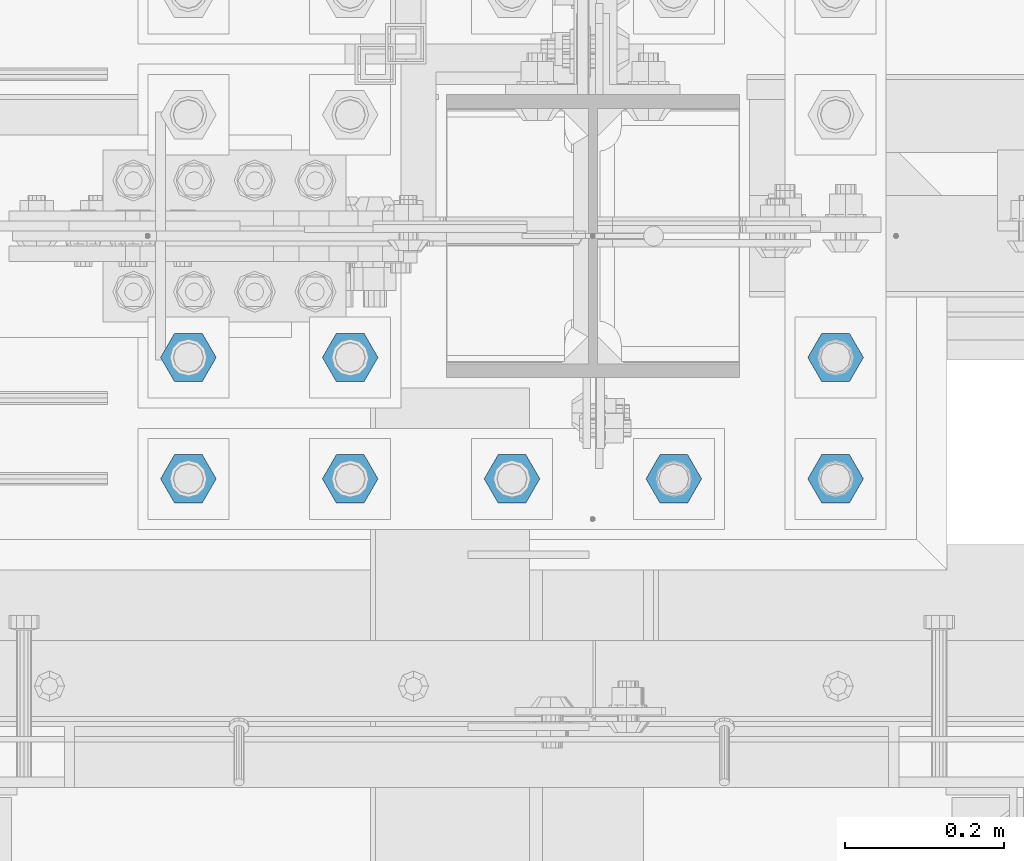
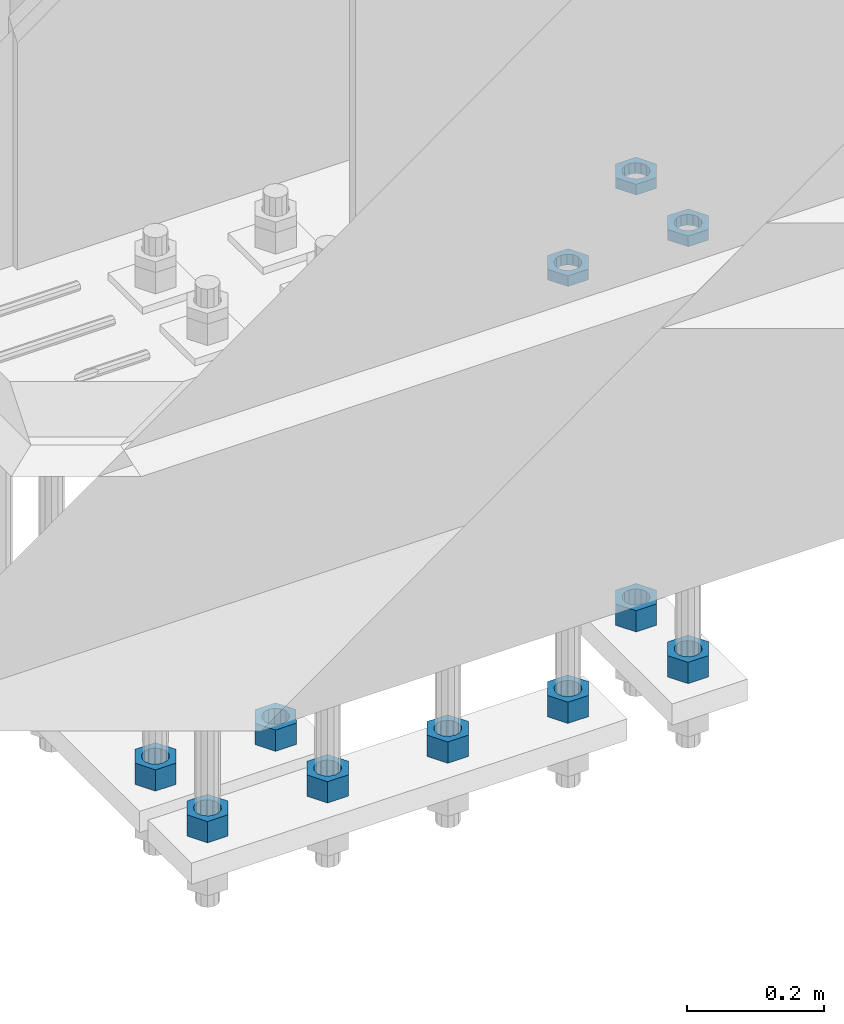
# One storey, part 2813 of 3843: 11 beams, 1 element without a shape of its own.
"""IFC2X3 building model written with IfcOpenShell, lengths in millimetres."""

from ifc_helpers import new_model, si_unit, frame, origin_with_axes, place, context, subcontext, project, spatial, faceted_brep, material, type_object, element, aggregate, save


model = new_model("IFC2X3")

# Units and contexts
model_context = context("Model", 3, precision=1e-05, world=origin_with_axes())
body_context = subcontext(model_context, "Body", "Model", "MODEL_VIEW")
ifc_project = project(units=[si_unit("LENGTHUNIT", "METRE", prefix="MILLI"), si_unit("AREAUNIT", "SQUARE_METRE"), si_unit("VOLUMEUNIT", "CUBIC_METRE"), si_unit("MASSUNIT", "GRAM", prefix="KILO"), si_unit("TIMEUNIT", "SECOND"), si_unit("PLANEANGLEUNIT", "RADIAN"), si_unit("SOLIDANGLEUNIT", "STERADIAN"), si_unit("THERMODYNAMICTEMPERATUREUNIT", "DEGREE_CELSIUS"), si_unit("LUMINOUSINTENSITYUNIT", "LUMEN")], contexts=[model_context])

# Site, building, storey
site_placement = place(None, origin_with_axes())
site = spatial("IfcSite", under=ifc_project, at=site_placement, CompositionType="ELEMENT")
building_placement = place(site_placement, origin_with_axes())
building = spatial("IfcBuilding", under=site, at=building_placement, Name="Undefined", CompositionType="ELEMENT")
storey_placement = place(building_placement, origin_with_axes())
storey = spatial("IfcBuildingStorey", under=building, at=storey_placement, Name="Undefined", CompositionType="ELEMENT", Elevation=0.0)

# Assembly, beams
assembly_placement = place(storey_placement, origin_with_axes())
assembly = element("IfcElementAssembly", 1, at=assembly_placement, inside=storey, Name="TEMPLATE", AssemblyPlace="NOTDEFINED", PredefinedType="RIGID_FRAME")
ifc_material = material(Name="STEEL/A572-50")
beam_type_1 = type_object("IfcBeamType", Name="1-1/2_HEAVY_HEX_NUT", PredefinedType="NOTDEFINED")
beam_1_placement = place(assembly_placement, frame((48488.6, 25463.5, 28841.7000015259), z_axis=(0.0, 1.0, 0.0), x_axis=(0.0, 0.0, -1.0)))
beam_1 = element("IfcBeam", 2, at=beam_1_placement, type_object=beam_type_1, material=ifc_material, Name="NUT", ObjectType="1-1/2_HEAVY_HEX_NUT", context=body_context, shape_type="Brep", body=[
    faceted_brep([(0.0, -34.9199981689453, 0.0), (0.0, -17.4599990844727, -30.25), (38.0999999999985, -17.4599990844727, -30.25), (38.0999999999985, -34.9199981689453, 0.0), (0.0, 17.4599990844727, -30.25), (38.0999999999985, 17.4599990844727, -30.25), (0.0, 34.9199981689453, 0.0), (38.0999999999985, 34.9199981689453, 0.0), (0.0, 17.4599990844727, 30.25), (38.0999999999985, 17.4599990844727, 30.25), (0.0, -17.4599990844727, 30.25), (38.0999999999985, -17.4599990844727, 30.25), (0.0, 0.0, 20.6399993896484), (0.0, 8.9553601105581, 18.5959968835959), (38.0999999999985, 8.9553601105581, 18.5959968835959), (38.0999999999985, 0.0, 20.6399993896484), (0.0, 16.1370013209525, 12.8688291298167), (38.0999999999985, 16.1370013209525, 12.8688291298167), (0.0, 20.1225115123816, 4.59283194104501), (38.0999999999985, 20.1225115123816, 4.59283194104501), (0.0, 20.1225115123816, -4.59283194104501), (38.0999999999985, 20.1225115123816, -4.59283194104501), (0.0, 16.1370013209525, -12.8688291298167), (38.0999999999985, 16.1370013209525, -12.8688291298167), (0.0, 8.9553601105581, -18.5959968835959), (38.0999999999985, 8.9553601105581, -18.5959968835959), (0.0, 0.0, -20.6399993896484), (38.0999999999985, 0.0, -20.6399993896484), (0.0, -8.9553601105581, -18.5959968835959), (38.0999999999985, -8.9553601105581, -18.5959968835959), (0.0, -16.1370013209525, -12.8688291298167), (38.0999999999985, -16.1370013209525, -12.8688291298167), (0.0, -20.1225115123816, -4.59283194104501), (38.0999999999985, -20.1225115123816, -4.59283194104501), (0.0, -20.1225115123816, 4.59283194104501), (38.0999999999985, -20.1225115123816, 4.59283194104501), (0.0, -16.1370013209525, 12.8688291298167), (38.0999999999985, -16.1370013209525, 12.8688291298167), (0.0, -8.9553601105581, 18.5959968835959), (38.0999999999985, -8.9553601105581, 18.5959968835959)], [[[0, 1, 2, 3]], [[1, 4, 5, 2]], [[4, 6, 7, 5]], [[6, 8, 9, 7]], [[8, 10, 11, 9]], [[10, 0, 3, 11]], [[12, 13, 14, 15]], [[13, 16, 17, 14]], [[16, 18, 19, 17]], [[18, 20, 21, 19]], [[20, 22, 23, 21]], [[22, 24, 25, 23]], [[24, 26, 27, 25]], [[26, 28, 29, 27]], [[28, 30, 31, 29]], [[30, 32, 33, 31]], [[32, 34, 35, 33]], [[34, 36, 37, 35]], [[36, 38, 39, 37]], [[38, 12, 15, 39]], [[5, 7, 9, 11, 3, 2], [17, 19, 21, 23, 25, 27, 29, 31, 33, 35, 37, 39, 15, 14]], [[10, 8, 6, 4, 1, 0], [38, 36, 34, 32, 30, 28, 26, 24, 22, 20, 18, 16, 13, 12]]]),
])
beam_2_placement = place(assembly_placement, frame((48691.8, 25463.5, 28841.7000015259), z_axis=(0.0, 1.0, 0.0), x_axis=(0.0, 0.0, -1.0)))
beam_2 = element("IfcBeam", 3, at=beam_2_placement, type_object=beam_type_1, material=ifc_material, Name="NUT", ObjectType="1-1/2_HEAVY_HEX_NUT", context=body_context, shape_type="Brep", body=[
    faceted_brep([(0.0, -34.9199981689453, 0.0), (0.0, -17.4599990844727, -30.25), (38.0999999999985, -17.4599990844727, -30.25), (38.0999999999985, -34.9199981689453, 0.0), (0.0, 17.4599990844727, -30.25), (38.0999999999985, 17.4599990844727, -30.25), (0.0, 34.9199981689453, 0.0), (38.0999999999985, 34.9199981689453, 0.0), (0.0, 17.4599990844727, 30.25), (38.0999999999985, 17.4599990844727, 30.25), (0.0, -17.4599990844727, 30.25), (38.0999999999985, -17.4599990844727, 30.25), (0.0, 0.0, 20.6399993896484), (0.0, 8.9553601105581, 18.5959968835959), (38.0999999999985, 8.9553601105581, 18.5959968835959), (38.0999999999985, 0.0, 20.6399993896484), (0.0, 16.1370013209525, 12.8688291298167), (38.0999999999985, 16.1370013209525, 12.8688291298167), (0.0, 20.1225115123816, 4.59283194104501), (38.0999999999985, 20.1225115123816, 4.59283194104501), (0.0, 20.1225115123816, -4.59283194104501), (38.0999999999985, 20.1225115123816, -4.59283194104501), (0.0, 16.1370013209525, -12.8688291298167), (38.0999999999985, 16.1370013209525, -12.8688291298167), (0.0, 8.9553601105581, -18.5959968835959), (38.0999999999985, 8.9553601105581, -18.5959968835959), (0.0, 0.0, -20.6399993896484), (38.0999999999985, 0.0, -20.6399993896484), (0.0, -8.9553601105581, -18.5959968835959), (38.0999999999985, -8.9553601105581, -18.5959968835959), (0.0, -16.1370013209525, -12.8688291298167), (38.0999999999985, -16.1370013209525, -12.8688291298167), (0.0, -20.1225115123816, -4.59283194104501), (38.0999999999985, -20.1225115123816, -4.59283194104501), (0.0, -20.1225115123816, 4.59283194104501), (38.0999999999985, -20.1225115123816, 4.59283194104501), (0.0, -16.1370013209525, 12.8688291298167), (38.0999999999985, -16.1370013209525, 12.8688291298167), (0.0, -8.9553601105581, 18.5959968835959), (38.0999999999985, -8.9553601105581, 18.5959968835959)], [[[0, 1, 2, 3]], [[1, 4, 5, 2]], [[4, 6, 7, 5]], [[6, 8, 9, 7]], [[8, 10, 11, 9]], [[10, 0, 3, 11]], [[12, 13, 14, 15]], [[13, 16, 17, 14]], [[16, 18, 19, 17]], [[18, 20, 21, 19]], [[20, 22, 23, 21]], [[22, 24, 25, 23]], [[24, 26, 27, 25]], [[26, 28, 29, 27]], [[28, 30, 31, 29]], [[30, 32, 33, 31]], [[32, 34, 35, 33]], [[34, 36, 37, 35]], [[36, 38, 39, 37]], [[38, 12, 15, 39]], [[5, 7, 9, 11, 3, 2], [17, 19, 21, 23, 25, 27, 29, 31, 33, 35, 37, 39, 15, 14]], [[10, 8, 6, 4, 1, 0], [38, 36, 34, 32, 30, 28, 26, 24, 22, 20, 18, 16, 13, 12]]]),
])
beam_3_placement = place(assembly_placement, frame((49301.4, 25463.5, 28841.7000015259), z_axis=(0.0, -1.0, 0.0), x_axis=(0.0, 0.0, -1.0)))
beam_3 = element("IfcBeam", 4, at=beam_3_placement, type_object=beam_type_1, material=ifc_material, Name="NUT", ObjectType="1-1/2_HEAVY_HEX_NUT", context=body_context, shape_type="Brep", body=[
    faceted_brep([(0.0, -34.9199981689453, 0.0), (0.0, -17.4599990844727, -30.25), (38.0999999999985, -17.4599990844727, -30.25), (38.0999999999985, -34.9199981689453, 0.0), (0.0, 17.4599990844727, -30.25), (38.0999999999985, 17.4599990844727, -30.25), (0.0, 34.9199981689453, 0.0), (38.0999999999985, 34.9199981689453, 0.0), (0.0, 17.4599990844727, 30.25), (38.0999999999985, 17.4599990844727, 30.25), (0.0, -17.4599990844727, 30.25), (38.0999999999985, -17.4599990844727, 30.25), (0.0, 0.0, 20.6399993896484), (0.0, 8.9553601105581, 18.5959968835959), (38.0999999999985, 8.9553601105581, 18.5959968835959), (38.0999999999985, 0.0, 20.6399993896484), (0.0, 16.1370013209525, 12.8688291298167), (38.0999999999985, 16.1370013209525, 12.8688291298167), (0.0, 20.1225115123816, 4.59283194104501), (38.0999999999985, 20.1225115123816, 4.59283194104501), (0.0, 20.1225115123816, -4.59283194104501), (38.0999999999985, 20.1225115123816, -4.59283194104501), (0.0, 16.1370013209525, -12.8688291298167), (38.0999999999985, 16.1370013209525, -12.8688291298167), (0.0, 8.9553601105581, -18.5959968835959), (38.0999999999985, 8.9553601105581, -18.5959968835959), (0.0, 0.0, -20.6399993896484), (38.0999999999985, 0.0, -20.6399993896484), (0.0, -8.9553601105581, -18.5959968835959), (38.0999999999985, -8.9553601105581, -18.5959968835959), (0.0, -16.1370013209525, -12.8688291298167), (38.0999999999985, -16.1370013209525, -12.8688291298167), (0.0, -20.1225115123816, -4.59283194104501), (38.0999999999985, -20.1225115123816, -4.59283194104501), (0.0, -20.1225115123816, 4.59283194104501), (38.0999999999985, -20.1225115123816, 4.59283194104501), (0.0, -16.1370013209525, 12.8688291298167), (38.0999999999985, -16.1370013209525, 12.8688291298167), (0.0, -8.9553601105581, 18.5959968835959), (38.0999999999985, -8.9553601105581, 18.5959968835959)], [[[0, 1, 2, 3]], [[1, 4, 5, 2]], [[4, 6, 7, 5]], [[6, 8, 9, 7]], [[8, 10, 11, 9]], [[10, 0, 3, 11]], [[12, 13, 14, 15]], [[13, 16, 17, 14]], [[16, 18, 19, 17]], [[18, 20, 21, 19]], [[20, 22, 23, 21]], [[22, 24, 25, 23]], [[24, 26, 27, 25]], [[26, 28, 29, 27]], [[28, 30, 31, 29]], [[30, 32, 33, 31]], [[32, 34, 35, 33]], [[34, 36, 37, 35]], [[36, 38, 39, 37]], [[38, 12, 15, 39]], [[5, 7, 9, 11, 3, 2], [17, 19, 21, 23, 25, 27, 29, 31, 33, 35, 37, 39, 15, 14]], [[10, 8, 6, 4, 1, 0], [38, 36, 34, 32, 30, 28, 26, 24, 22, 20, 18, 16, 13, 12]]]),
])
beam_4_placement = place(assembly_placement, frame((49301.4, 25311.1, 28841.7000015259), z_axis=(0.0, -1.0, 0.0), x_axis=(0.0, 0.0, -1.0)))
beam_4 = element("IfcBeam", 5, at=beam_4_placement, type_object=beam_type_1, material=ifc_material, Name="NUT", ObjectType="1-1/2_HEAVY_HEX_NUT", context=body_context, shape_type="Brep", body=[
    faceted_brep([(0.0, -34.9199981689453, 0.0), (0.0, -17.4599990844727, -30.25), (38.0999999999985, -17.4599990844727, -30.25), (38.0999999999985, -34.9199981689453, 0.0), (0.0, 17.4599990844727, -30.25), (38.0999999999985, 17.4599990844727, -30.25), (0.0, 34.9199981689453, 0.0), (38.0999999999985, 34.9199981689453, 0.0), (0.0, 17.4599990844727, 30.25), (38.0999999999985, 17.4599990844727, 30.25), (0.0, -17.4599990844727, 30.25), (38.0999999999985, -17.4599990844727, 30.25), (0.0, 0.0, 20.6399993896484), (0.0, 8.9553601105581, 18.5959968835959), (38.0999999999985, 8.9553601105581, 18.5959968835959), (38.0999999999985, 0.0, 20.6399993896484), (0.0, 16.1370013209525, 12.8688291298167), (38.0999999999985, 16.1370013209525, 12.8688291298167), (0.0, 20.1225115123816, 4.59283194104501), (38.0999999999985, 20.1225115123816, 4.59283194104501), (0.0, 20.1225115123816, -4.59283194104501), (38.0999999999985, 20.1225115123816, -4.59283194104501), (0.0, 16.1370013209525, -12.8688291298167), (38.0999999999985, 16.1370013209525, -12.8688291298167), (0.0, 8.9553601105581, -18.5959968835959), (38.0999999999985, 8.9553601105581, -18.5959968835959), (0.0, 0.0, -20.6399993896484), (38.0999999999985, 0.0, -20.6399993896484), (0.0, -8.9553601105581, -18.5959968835959), (38.0999999999985, -8.9553601105581, -18.5959968835959), (0.0, -16.1370013209525, -12.8688291298167), (38.0999999999985, -16.1370013209525, -12.8688291298167), (0.0, -20.1225115123816, -4.59283194104501), (38.0999999999985, -20.1225115123816, -4.59283194104501), (0.0, -20.1225115123816, 4.59283194104501), (38.0999999999985, -20.1225115123816, 4.59283194104501), (0.0, -16.1370013209525, 12.8688291298167), (38.0999999999985, -16.1370013209525, 12.8688291298167), (0.0, -8.9553601105581, 18.5959968835959), (38.0999999999985, -8.9553601105581, 18.5959968835959)], [[[0, 1, 2, 3]], [[1, 4, 5, 2]], [[4, 6, 7, 5]], [[6, 8, 9, 7]], [[8, 10, 11, 9]], [[10, 0, 3, 11]], [[12, 13, 14, 15]], [[13, 16, 17, 14]], [[16, 18, 19, 17]], [[18, 20, 21, 19]], [[20, 22, 23, 21]], [[22, 24, 25, 23]], [[24, 26, 27, 25]], [[26, 28, 29, 27]], [[28, 30, 31, 29]], [[30, 32, 33, 31]], [[32, 34, 35, 33]], [[34, 36, 37, 35]], [[36, 38, 39, 37]], [[38, 12, 15, 39]], [[5, 7, 9, 11, 3, 2], [17, 19, 21, 23, 25, 27, 29, 31, 33, 35, 37, 39, 15, 14]], [[10, 8, 6, 4, 1, 0], [38, 36, 34, 32, 30, 28, 26, 24, 22, 20, 18, 16, 13, 12]]]),
])
beam_5_placement = place(assembly_placement, frame((49098.2, 25311.1, 28841.7000015259), z_axis=(0.0, -1.0, 0.0), x_axis=(0.0, 0.0, -1.0)))
beam_5 = element("IfcBeam", 6, at=beam_5_placement, type_object=beam_type_1, material=ifc_material, Name="NUT", ObjectType="1-1/2_HEAVY_HEX_NUT", context=body_context, shape_type="Brep", body=[
    faceted_brep([(0.0, -34.9199981689453, 0.0), (0.0, -17.4599990844727, -30.25), (38.0999999999985, -17.4599990844727, -30.25), (38.0999999999985, -34.9199981689453, 0.0), (0.0, 17.4599990844727, -30.25), (38.0999999999985, 17.4599990844727, -30.25), (0.0, 34.9199981689453, 0.0), (38.0999999999985, 34.9199981689453, 0.0), (0.0, 17.4599990844727, 30.25), (38.0999999999985, 17.4599990844727, 30.25), (0.0, -17.4599990844727, 30.25), (38.0999999999985, -17.4599990844727, 30.25), (0.0, 0.0, 20.6399993896484), (0.0, 8.9553601105581, 18.5959968835959), (38.0999999999985, 8.9553601105581, 18.5959968835959), (38.0999999999985, 0.0, 20.6399993896484), (0.0, 16.1370013209525, 12.8688291298167), (38.0999999999985, 16.1370013209525, 12.8688291298167), (0.0, 20.1225115123816, 4.59283194104501), (38.0999999999985, 20.1225115123816, 4.59283194104501), (0.0, 20.1225115123816, -4.59283194104501), (38.0999999999985, 20.1225115123816, -4.59283194104501), (0.0, 16.1370013209525, -12.8688291298167), (38.0999999999985, 16.1370013209525, -12.8688291298167), (0.0, 8.9553601105581, -18.5959968835959), (38.0999999999985, 8.9553601105581, -18.5959968835959), (0.0, 0.0, -20.6399993896484), (38.0999999999985, 0.0, -20.6399993896484), (0.0, -8.9553601105581, -18.5959968835959), (38.0999999999985, -8.9553601105581, -18.5959968835959), (0.0, -16.1370013209525, -12.8688291298167), (38.0999999999985, -16.1370013209525, -12.8688291298167), (0.0, -20.1225115123816, -4.59283194104501), (38.0999999999985, -20.1225115123816, -4.59283194104501), (0.0, -20.1225115123816, 4.59283194104501), (38.0999999999985, -20.1225115123816, 4.59283194104501), (0.0, -16.1370013209525, 12.8688291298167), (38.0999999999985, -16.1370013209525, 12.8688291298167), (0.0, -8.9553601105581, 18.5959968835959), (38.0999999999985, -8.9553601105581, 18.5959968835959)], [[[0, 1, 2, 3]], [[1, 4, 5, 2]], [[4, 6, 7, 5]], [[6, 8, 9, 7]], [[8, 10, 11, 9]], [[10, 0, 3, 11]], [[12, 13, 14, 15]], [[13, 16, 17, 14]], [[16, 18, 19, 17]], [[18, 20, 21, 19]], [[20, 22, 23, 21]], [[22, 24, 25, 23]], [[24, 26, 27, 25]], [[26, 28, 29, 27]], [[28, 30, 31, 29]], [[30, 32, 33, 31]], [[32, 34, 35, 33]], [[34, 36, 37, 35]], [[36, 38, 39, 37]], [[38, 12, 15, 39]], [[5, 7, 9, 11, 3, 2], [17, 19, 21, 23, 25, 27, 29, 31, 33, 35, 37, 39, 15, 14]], [[10, 8, 6, 4, 1, 0], [38, 36, 34, 32, 30, 28, 26, 24, 22, 20, 18, 16, 13, 12]]]),
])
beam_6_placement = place(assembly_placement, frame((48895.0, 25311.1, 28841.7000015259), z_axis=(0.0, -1.0, 0.0), x_axis=(0.0, 0.0, -1.0)))
beam_6 = element("IfcBeam", 7, at=beam_6_placement, type_object=beam_type_1, material=ifc_material, Name="NUT", ObjectType="1-1/2_HEAVY_HEX_NUT", context=body_context, shape_type="Brep", body=[
    faceted_brep([(0.0, -34.9199981689453, 0.0), (0.0, -17.4599990844727, -30.25), (38.0999999999985, -17.4599990844727, -30.25), (38.0999999999985, -34.9199981689453, 0.0), (0.0, 17.4599990844727, -30.25), (38.0999999999985, 17.4599990844727, -30.25), (0.0, 34.9199981689453, 0.0), (38.0999999999985, 34.9199981689453, 0.0), (0.0, 17.4599990844727, 30.25), (38.0999999999985, 17.4599990844727, 30.25), (0.0, -17.4599990844727, 30.25), (38.0999999999985, -17.4599990844727, 30.25), (0.0, 0.0, 20.6399993896484), (0.0, 8.9553601105581, 18.5959968835959), (38.0999999999985, 8.9553601105581, 18.5959968835959), (38.0999999999985, 0.0, 20.6399993896484), (0.0, 16.1370013209525, 12.8688291298167), (38.0999999999985, 16.1370013209525, 12.8688291298167), (0.0, 20.1225115123816, 4.59283194104501), (38.0999999999985, 20.1225115123816, 4.59283194104501), (0.0, 20.1225115123816, -4.59283194104501), (38.0999999999985, 20.1225115123816, -4.59283194104501), (0.0, 16.1370013209525, -12.8688291298167), (38.0999999999985, 16.1370013209525, -12.8688291298167), (0.0, 8.9553601105581, -18.5959968835959), (38.0999999999985, 8.9553601105581, -18.5959968835959), (0.0, 0.0, -20.6399993896484), (38.0999999999985, 0.0, -20.6399993896484), (0.0, -8.9553601105581, -18.5959968835959), (38.0999999999985, -8.9553601105581, -18.5959968835959), (0.0, -16.1370013209525, -12.8688291298167), (38.0999999999985, -16.1370013209525, -12.8688291298167), (0.0, -20.1225115123816, -4.59283194104501), (38.0999999999985, -20.1225115123816, -4.59283194104501), (0.0, -20.1225115123816, 4.59283194104501), (38.0999999999985, -20.1225115123816, 4.59283194104501), (0.0, -16.1370013209525, 12.8688291298167), (38.0999999999985, -16.1370013209525, 12.8688291298167), (0.0, -8.9553601105581, 18.5959968835959), (38.0999999999985, -8.9553601105581, 18.5959968835959)], [[[0, 1, 2, 3]], [[1, 4, 5, 2]], [[4, 6, 7, 5]], [[6, 8, 9, 7]], [[8, 10, 11, 9]], [[10, 0, 3, 11]], [[12, 13, 14, 15]], [[13, 16, 17, 14]], [[16, 18, 19, 17]], [[18, 20, 21, 19]], [[20, 22, 23, 21]], [[22, 24, 25, 23]], [[24, 26, 27, 25]], [[26, 28, 29, 27]], [[28, 30, 31, 29]], [[30, 32, 33, 31]], [[32, 34, 35, 33]], [[34, 36, 37, 35]], [[36, 38, 39, 37]], [[38, 12, 15, 39]], [[5, 7, 9, 11, 3, 2], [17, 19, 21, 23, 25, 27, 29, 31, 33, 35, 37, 39, 15, 14]], [[10, 8, 6, 4, 1, 0], [38, 36, 34, 32, 30, 28, 26, 24, 22, 20, 18, 16, 13, 12]]]),
])
beam_7_placement = place(assembly_placement, frame((48691.8, 25311.1, 28841.7000015259), z_axis=(0.0, 1.0, 0.0), x_axis=(0.0, 0.0, -1.0)))
beam_7 = element("IfcBeam", 8, at=beam_7_placement, type_object=beam_type_1, material=ifc_material, Name="NUT", ObjectType="1-1/2_HEAVY_HEX_NUT", context=body_context, shape_type="Brep", body=[
    faceted_brep([(0.0, -34.9199981689453, 0.0), (0.0, -17.4599990844727, -30.25), (38.0999999999985, -17.4599990844727, -30.25), (38.0999999999985, -34.9199981689453, 0.0), (0.0, 17.4599990844727, -30.25), (38.0999999999985, 17.4599990844727, -30.25), (0.0, 34.9199981689453, 0.0), (38.0999999999985, 34.9199981689453, 0.0), (0.0, 17.4599990844727, 30.25), (38.0999999999985, 17.4599990844727, 30.25), (0.0, -17.4599990844727, 30.25), (38.0999999999985, -17.4599990844727, 30.25), (0.0, 0.0, 20.6399993896484), (0.0, 8.9553601105581, 18.5959968835959), (38.0999999999985, 8.9553601105581, 18.5959968835959), (38.0999999999985, 0.0, 20.6399993896484), (0.0, 16.1370013209525, 12.8688291298167), (38.0999999999985, 16.1370013209525, 12.8688291298167), (0.0, 20.1225115123816, 4.59283194104501), (38.0999999999985, 20.1225115123816, 4.59283194104501), (0.0, 20.1225115123816, -4.59283194104501), (38.0999999999985, 20.1225115123816, -4.59283194104501), (0.0, 16.1370013209525, -12.8688291298167), (38.0999999999985, 16.1370013209525, -12.8688291298167), (0.0, 8.9553601105581, -18.5959968835959), (38.0999999999985, 8.9553601105581, -18.5959968835959), (0.0, 0.0, -20.6399993896484), (38.0999999999985, 0.0, -20.6399993896484), (0.0, -8.9553601105581, -18.5959968835959), (38.0999999999985, -8.9553601105581, -18.5959968835959), (0.0, -16.1370013209525, -12.8688291298167), (38.0999999999985, -16.1370013209525, -12.8688291298167), (0.0, -20.1225115123816, -4.59283194104501), (38.0999999999985, -20.1225115123816, -4.59283194104501), (0.0, -20.1225115123816, 4.59283194104501), (38.0999999999985, -20.1225115123816, 4.59283194104501), (0.0, -16.1370013209525, 12.8688291298167), (38.0999999999985, -16.1370013209525, 12.8688291298167), (0.0, -8.9553601105581, 18.5959968835959), (38.0999999999985, -8.9553601105581, 18.5959968835959)], [[[0, 1, 2, 3]], [[1, 4, 5, 2]], [[4, 6, 7, 5]], [[6, 8, 9, 7]], [[8, 10, 11, 9]], [[10, 0, 3, 11]], [[12, 13, 14, 15]], [[13, 16, 17, 14]], [[16, 18, 19, 17]], [[18, 20, 21, 19]], [[20, 22, 23, 21]], [[22, 24, 25, 23]], [[24, 26, 27, 25]], [[26, 28, 29, 27]], [[28, 30, 31, 29]], [[30, 32, 33, 31]], [[32, 34, 35, 33]], [[34, 36, 37, 35]], [[36, 38, 39, 37]], [[38, 12, 15, 39]], [[5, 7, 9, 11, 3, 2], [17, 19, 21, 23, 25, 27, 29, 31, 33, 35, 37, 39, 15, 14]], [[10, 8, 6, 4, 1, 0], [38, 36, 34, 32, 30, 28, 26, 24, 22, 20, 18, 16, 13, 12]]]),
])
beam_8_placement = place(assembly_placement, frame((48488.6, 25311.1, 28841.7000015259), z_axis=(0.0, 1.0, 0.0), x_axis=(0.0, 0.0, -1.0)))
beam_8 = element("IfcBeam", 9, at=beam_8_placement, type_object=beam_type_1, material=ifc_material, Name="NUT", ObjectType="1-1/2_HEAVY_HEX_NUT", context=body_context, shape_type="Brep", body=[
    faceted_brep([(0.0, -34.9199981689453, 0.0), (0.0, -17.4599990844727, -30.25), (38.0999999999985, -17.4599990844727, -30.25), (38.0999999999985, -34.9199981689453, 0.0), (0.0, 17.4599990844727, -30.25), (38.0999999999985, 17.4599990844727, -30.25), (0.0, 34.9199981689453, 0.0), (38.0999999999985, 34.9199981689453, 0.0), (0.0, 17.4599990844727, 30.25), (38.0999999999985, 17.4599990844727, 30.25), (0.0, -17.4599990844727, 30.25), (38.0999999999985, -17.4599990844727, 30.25), (0.0, 0.0, 20.6399993896484), (0.0, 8.9553601105581, 18.5959968835959), (38.0999999999985, 8.9553601105581, 18.5959968835959), (38.0999999999985, 0.0, 20.6399993896484), (0.0, 16.1370013209525, 12.8688291298167), (38.0999999999985, 16.1370013209525, 12.8688291298167), (0.0, 20.1225115123816, 4.59283194104501), (38.0999999999985, 20.1225115123816, 4.59283194104501), (0.0, 20.1225115123816, -4.59283194104501), (38.0999999999985, 20.1225115123816, -4.59283194104501), (0.0, 16.1370013209525, -12.8688291298167), (38.0999999999985, 16.1370013209525, -12.8688291298167), (0.0, 8.9553601105581, -18.5959968835959), (38.0999999999985, 8.9553601105581, -18.5959968835959), (0.0, 0.0, -20.6399993896484), (38.0999999999985, 0.0, -20.6399993896484), (0.0, -8.9553601105581, -18.5959968835959), (38.0999999999985, -8.9553601105581, -18.5959968835959), (0.0, -16.1370013209525, -12.8688291298167), (38.0999999999985, -16.1370013209525, -12.8688291298167), (0.0, -20.1225115123816, -4.59283194104501), (38.0999999999985, -20.1225115123816, -4.59283194104501), (0.0, -20.1225115123816, 4.59283194104501), (38.0999999999985, -20.1225115123816, 4.59283194104501), (0.0, -16.1370013209525, 12.8688291298167), (38.0999999999985, -16.1370013209525, 12.8688291298167), (0.0, -8.9553601105581, 18.5959968835959), (38.0999999999985, -8.9553601105581, 18.5959968835959)], [[[0, 1, 2, 3]], [[1, 4, 5, 2]], [[4, 6, 7, 5]], [[6, 8, 9, 7]], [[8, 10, 11, 9]], [[10, 0, 3, 11]], [[12, 13, 14, 15]], [[13, 16, 17, 14]], [[16, 18, 19, 17]], [[18, 20, 21, 19]], [[20, 22, 23, 21]], [[22, 24, 25, 23]], [[24, 26, 27, 25]], [[26, 28, 29, 27]], [[28, 30, 31, 29]], [[30, 32, 33, 31]], [[32, 34, 35, 33]], [[34, 36, 37, 35]], [[36, 38, 39, 37]], [[38, 12, 15, 39]], [[5, 7, 9, 11, 3, 2], [17, 19, 21, 23, 25, 27, 29, 31, 33, 35, 37, 39, 15, 14]], [[10, 8, 6, 4, 1, 0], [38, 36, 34, 32, 30, 28, 26, 24, 22, 20, 18, 16, 13, 12]]]),
])
beam_type_2 = type_object("IfcBeamType", Name="1-1/2_HALF_NUT", PredefinedType="NOTDEFINED")
beam_9_placement = place(assembly_placement, frame((49301.4, 25463.5, 29603.7), z_axis=(0.0, 1.0, 0.0), x_axis=(0.0, 0.0, -1.0)))
beam_9 = element("IfcBeam", 10, at=beam_9_placement, type_object=beam_type_2, material=ifc_material, Name="NUT", ObjectType="1-1/2_HALF_NUT", context=body_context, shape_type="Brep", body=[
    faceted_brep([(0.0, -34.9199981689453, 0.0), (0.0, -17.4599990844727, -30.25), (19.0500000000029, -17.4599990844727, -30.25), (19.0500000000029, -34.9199981689453, 0.0), (0.0, 17.4599990844727, -30.25), (19.0500000000029, 17.4599990844727, -30.25), (0.0, 34.9199981689453, 0.0), (19.0500000000029, 34.9199981689453, 0.0), (0.0, 17.4599990844727, 30.25), (19.0500000000029, 17.4599990844727, 30.25), (0.0, -17.4599990844727, 30.25), (19.0500000000029, -17.4599990844727, 30.25), (0.0, 0.0, 20.6399993896484), (0.0, 8.9553601105581, 18.5959968835959), (19.0500000000029, 8.95536011056538, 18.5959968835959), (19.0500000000029, 0.0, 20.6399993896484), (0.0, 16.1370013209525, 12.8688291298167), (19.0500000000029, 16.1370013209489, 12.8688291298167), (0.0, 20.1225115123816, 4.59283194104501), (19.0500000000029, 20.1225115123852, 4.59283194104501), (0.0, 20.1225115123816, -4.59283194104501), (19.0500000000029, 20.1225115123852, -4.59283194104501), (0.0, 16.1370013209525, -12.8688291298167), (19.0500000000029, 16.1370013209489, -12.8688291298167), (0.0, 8.9553601105581, -18.5959968835959), (19.0500000000029, 8.95536011056538, -18.5959968835959), (0.0, 0.0, -20.6399993896484), (19.0500000000029, 0.0, -20.6399993896484), (0.0, -8.9553601105581, -18.5959968835959), (19.0500000000029, -8.95536011056538, -18.5959968835959), (0.0, -16.1370013209525, -12.8688291298167), (19.0500000000029, -16.1370013209489, -12.8688291298167), (0.0, -20.1225115123816, -4.59283194104501), (19.0500000000029, -20.1225115123852, -4.59283194104501), (0.0, -20.1225115123816, 4.59283194104501), (19.0500000000029, -20.1225115123852, 4.59283194104501), (0.0, -16.1370013209525, 12.8688291298167), (19.0500000000029, -16.1370013209489, 12.8688291298167), (0.0, -8.9553601105581, 18.5959968835959), (19.0500000000029, -8.95536011056538, 18.5959968835959)], [[[0, 1, 2, 3]], [[1, 4, 5, 2]], [[4, 6, 7, 5]], [[6, 8, 9, 7]], [[8, 10, 11, 9]], [[10, 0, 3, 11]], [[12, 13, 14, 15]], [[13, 16, 17, 14]], [[16, 18, 19, 17]], [[18, 20, 21, 19]], [[20, 22, 23, 21]], [[22, 24, 25, 23]], [[24, 26, 27, 25]], [[26, 28, 29, 27]], [[28, 30, 31, 29]], [[30, 32, 33, 31]], [[32, 34, 35, 33]], [[34, 36, 37, 35]], [[36, 38, 39, 37]], [[38, 12, 15, 39]], [[5, 7, 9, 11, 3, 2], [17, 19, 21, 23, 25, 27, 29, 31, 33, 35, 37, 39, 15, 14]], [[10, 8, 6, 4, 1, 0], [38, 36, 34, 32, 30, 28, 26, 24, 22, 20, 18, 16, 13, 12]]]),
])
beam_10_placement = place(assembly_placement, frame((49301.4, 25311.1, 29603.7), z_axis=(0.0, 1.0, 0.0), x_axis=(0.0, 0.0, -1.0)))
beam_10 = element("IfcBeam", 11, at=beam_10_placement, type_object=beam_type_2, material=ifc_material, Name="NUT", ObjectType="1-1/2_HALF_NUT", context=body_context, shape_type="Brep", body=[
    faceted_brep([(0.0, -34.9199981689453, 0.0), (0.0, -17.4599990844727, -30.25), (19.0500000000029, -17.4599990844727, -30.25), (19.0500000000029, -34.9199981689453, 0.0), (0.0, 17.4599990844727, -30.25), (19.0500000000029, 17.4599990844727, -30.25), (0.0, 34.9199981689453, 0.0), (19.0500000000029, 34.9199981689453, 0.0), (0.0, 17.4599990844727, 30.25), (19.0500000000029, 17.4599990844727, 30.25), (0.0, -17.4599990844727, 30.25), (19.0500000000029, -17.4599990844727, 30.25), (0.0, 0.0, 20.6399993896484), (0.0, 8.9553601105581, 18.5959968835959), (19.0500000000029, 8.95536011056538, 18.5959968835959), (19.0500000000029, 0.0, 20.6399993896484), (0.0, 16.1370013209525, 12.8688291298167), (19.0500000000029, 16.1370013209489, 12.8688291298167), (0.0, 20.1225115123816, 4.59283194104501), (19.0500000000029, 20.1225115123852, 4.59283194104501), (0.0, 20.1225115123816, -4.59283194104501), (19.0500000000029, 20.1225115123852, -4.59283194104501), (0.0, 16.1370013209525, -12.8688291298167), (19.0500000000029, 16.1370013209489, -12.8688291298167), (0.0, 8.9553601105581, -18.5959968835959), (19.0500000000029, 8.95536011056538, -18.5959968835959), (0.0, 0.0, -20.6399993896484), (19.0500000000029, 0.0, -20.6399993896484), (0.0, -8.9553601105581, -18.5959968835959), (19.0500000000029, -8.95536011056538, -18.5959968835959), (0.0, -16.1370013209525, -12.8688291298167), (19.0500000000029, -16.1370013209489, -12.8688291298167), (0.0, -20.1225115123816, -4.59283194104501), (19.0500000000029, -20.1225115123852, -4.59283194104501), (0.0, -20.1225115123816, 4.59283194104501), (19.0500000000029, -20.1225115123852, 4.59283194104501), (0.0, -16.1370013209525, 12.8688291298167), (19.0500000000029, -16.1370013209489, 12.8688291298167), (0.0, -8.9553601105581, 18.5959968835959), (19.0500000000029, -8.95536011056538, 18.5959968835959)], [[[0, 1, 2, 3]], [[1, 4, 5, 2]], [[4, 6, 7, 5]], [[6, 8, 9, 7]], [[8, 10, 11, 9]], [[10, 0, 3, 11]], [[12, 13, 14, 15]], [[13, 16, 17, 14]], [[16, 18, 19, 17]], [[18, 20, 21, 19]], [[20, 22, 23, 21]], [[22, 24, 25, 23]], [[24, 26, 27, 25]], [[26, 28, 29, 27]], [[28, 30, 31, 29]], [[30, 32, 33, 31]], [[32, 34, 35, 33]], [[34, 36, 37, 35]], [[36, 38, 39, 37]], [[38, 12, 15, 39]], [[5, 7, 9, 11, 3, 2], [17, 19, 21, 23, 25, 27, 29, 31, 33, 35, 37, 39, 15, 14]], [[10, 8, 6, 4, 1, 0], [38, 36, 34, 32, 30, 28, 26, 24, 22, 20, 18, 16, 13, 12]]]),
])
beam_11_placement = place(assembly_placement, frame((49098.2, 25311.1, 29603.7), z_axis=(0.0, 1.0, 0.0), x_axis=(0.0, 0.0, -1.0)))
beam_11 = element("IfcBeam", 12, at=beam_11_placement, type_object=beam_type_2, material=ifc_material, Name="NUT", ObjectType="1-1/2_HALF_NUT", context=body_context, shape_type="Brep", body=[
    faceted_brep([(0.0, -34.9199981689453, 0.0), (0.0, -17.4599990844727, -30.25), (19.0500000000029, -17.4599990844727, -30.25), (19.0500000000029, -34.9199981689453, 0.0), (0.0, 17.4599990844727, -30.25), (19.0500000000029, 17.4599990844727, -30.25), (0.0, 34.9199981689453, 0.0), (19.0500000000029, 34.9199981689453, 0.0), (0.0, 17.4599990844727, 30.25), (19.0500000000029, 17.4599990844727, 30.25), (0.0, -17.4599990844727, 30.25), (19.0500000000029, -17.4599990844727, 30.25), (0.0, 0.0, 20.6399993896484), (0.0, 8.9553601105581, 18.5959968835959), (19.0500000000029, 8.95536011056538, 18.5959968835959), (19.0500000000029, 0.0, 20.6399993896484), (0.0, 16.1370013209525, 12.8688291298167), (19.0500000000029, 16.1370013209489, 12.8688291298167), (0.0, 20.1225115123816, 4.59283194104501), (19.0500000000029, 20.1225115123852, 4.59283194104501), (0.0, 20.1225115123816, -4.59283194104501), (19.0500000000029, 20.1225115123852, -4.59283194104501), (0.0, 16.1370013209525, -12.8688291298167), (19.0500000000029, 16.1370013209489, -12.8688291298167), (0.0, 8.9553601105581, -18.5959968835959), (19.0500000000029, 8.95536011056538, -18.5959968835959), (0.0, 0.0, -20.6399993896484), (19.0500000000029, 0.0, -20.6399993896484), (0.0, -8.9553601105581, -18.5959968835959), (19.0500000000029, -8.95536011056538, -18.5959968835959), (0.0, -16.1370013209525, -12.8688291298167), (19.0500000000029, -16.1370013209489, -12.8688291298167), (0.0, -20.1225115123816, -4.59283194104501), (19.0500000000029, -20.1225115123852, -4.59283194104501), (0.0, -20.1225115123816, 4.59283194104501), (19.0500000000029, -20.1225115123852, 4.59283194104501), (0.0, -16.1370013209525, 12.8688291298167), (19.0500000000029, -16.1370013209489, 12.8688291298167), (0.0, -8.9553601105581, 18.5959968835959), (19.0500000000029, -8.95536011056538, 18.5959968835959)], [[[0, 1, 2, 3]], [[1, 4, 5, 2]], [[4, 6, 7, 5]], [[6, 8, 9, 7]], [[8, 10, 11, 9]], [[10, 0, 3, 11]], [[12, 13, 14, 15]], [[13, 16, 17, 14]], [[16, 18, 19, 17]], [[18, 20, 21, 19]], [[20, 22, 23, 21]], [[22, 24, 25, 23]], [[24, 26, 27, 25]], [[26, 28, 29, 27]], [[28, 30, 31, 29]], [[30, 32, 33, 31]], [[32, 34, 35, 33]], [[34, 36, 37, 35]], [[36, 38, 39, 37]], [[38, 12, 15, 39]], [[5, 7, 9, 11, 3, 2], [17, 19, 21, 23, 25, 27, 29, 31, 33, 35, 37, 39, 15, 14]], [[10, 8, 6, 4, 1, 0], [38, 36, 34, 32, 30, 28, 26, 24, 22, 20, 18, 16, 13, 12]]]),
])
aggregate(assembly, [beam_1, beam_2, beam_3, beam_4, beam_5, beam_6, beam_7, beam_8, beam_9, beam_10, beam_11])

save(model, "model.ifc")
